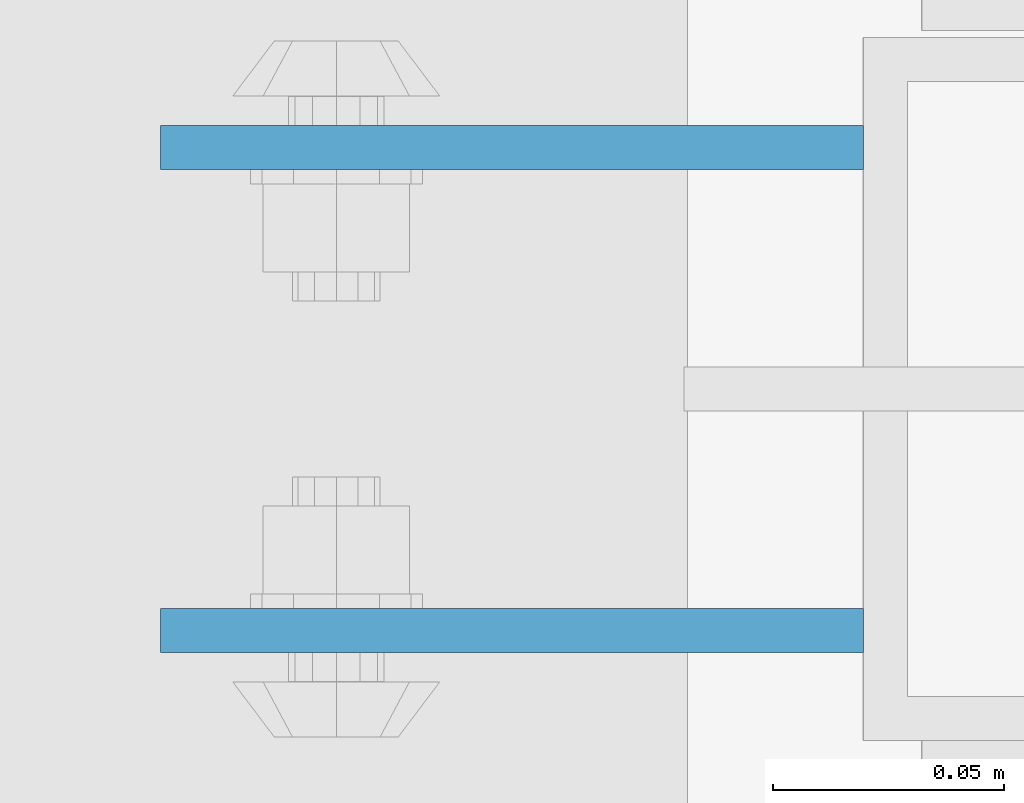
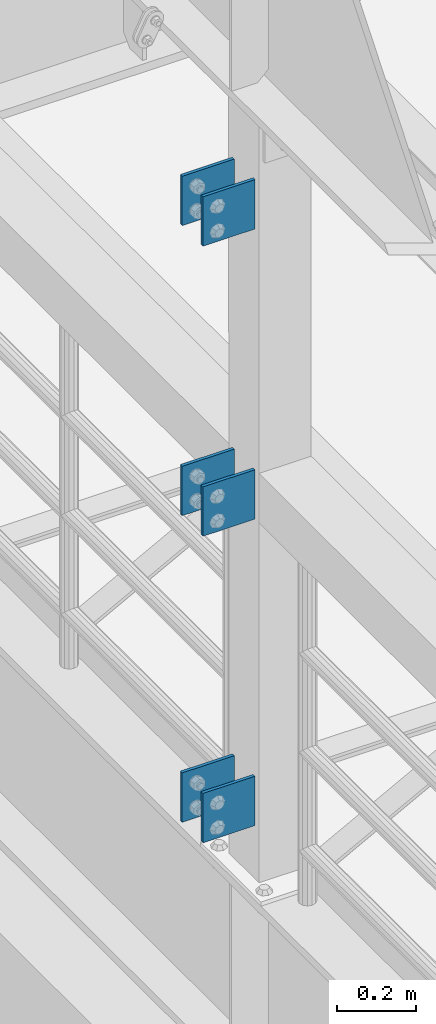
# One storey, part 1182 of 1876: 6 beams, 1 element without a shape of its own.
"""IFC2X3 building model written with IfcOpenShell, lengths in millimetres."""

import ifcopenshell
import ifcopenshell.guid

model = None  # the IFC model being written
_history = None  # IfcOwnerHistory: only IFC2X3 demands one
_inside = {}  # id of a spatial element -> (the spatial element, [elements in it])
_under = {}  # id of a project, library or spatial element -> (it, [spatial elements below it])
_declared = {}  # id of a project -> (the project, [libraries it declares])
_typed = {}  # id of a type object -> (the type object, [elements of that type])
_made_of = {}  # id of a material, layer set ... -> (it, [elements and type objects made of it])


def new_model(schema):
    """Start an empty IFC model of exactly this schema.

    Asked for "IFC4X3", IfcOpenShell would pick the latest addendum, in which some entities
    have other attributes; the version numbers below select the first issue.
    IFC2X3 requires an IfcOwnerHistory on every rooted entity: one is made here for all.
    """
    global model, _history
    if schema == "IFC4X3":
        model = ifcopenshell.file(schema_version=(4, 3, 0, 0))
    else:
        model = ifcopenshell.file(schema=schema)
    _inside.clear()
    _under.clear()
    _declared.clear()
    _typed.clear()
    _made_of.clear()
    _history = None
    if model.schema == "IFC2X3":
        org = make("IfcOrganization", Name="unknown")
        user = make(
            "IfcPersonAndOrganization",
            ThePerson=make("IfcPerson", FamilyName="unknown"),
            TheOrganization=org,
        )
        app = make(
            "IfcApplication",
            ApplicationDeveloper=org,
            Version="unknown",
            ApplicationFullName="unknown",
            ApplicationIdentifier="unknown",
        )
        _history = make(
            "IfcOwnerHistory",
            OwningUser=user,
            OwningApplication=app,
            ChangeAction="ADDED",
            CreationDate=0,
        )
    return model


def make(cls, **values):
    """One entity of the class cls with the attributes given. An attribute that is None is left unset."""
    return model.create_entity(
        cls, **{name: value for name, value in values.items() if value is not None}
    )


def rooted(cls, **values):
    """An entity with a GlobalId (a new one), such as an element, a storey or a relation."""
    return make(cls, GlobalId=ifcopenshell.guid.new(), OwnerHistory=_history, **values)


def si_unit(unit_type, name, prefix=None):
    """IfcSIUnit, for example si_unit("LENGTHUNIT", "METRE", prefix="MILLI")."""
    return make("IfcSIUnit", UnitType=unit_type, Prefix=prefix, Name=name)


def assignment(units):
    """IfcUnitAssignment: the units of a project."""
    return None if units is None else make("IfcUnitAssignment", Units=units)


def point(xyz):
    """IfcCartesianPoint."""
    return None if xyz is None else make("IfcCartesianPoint", Coordinates=xyz)


def direction(xyz):
    """IfcDirection."""
    return None if xyz is None else make("IfcDirection", DirectionRatios=xyz)


def frame(location, z_axis=None, x_axis=None):
    """IfcAxis2Placement3D, a coordinate frame: its origin and axes. An axis left out is left unset."""
    return make(
        "IfcAxis2Placement3D",
        Location=point(location),
        Axis=direction(z_axis),
        RefDirection=direction(x_axis),
    )


def origin_with_axes():
    """The frame at (0, 0, 0) with the z axis (0, 0, 1) and the x axis (1, 0, 0) written out."""
    return frame((0.0, 0.0, 0.0), z_axis=(0.0, 0.0, 1.0), x_axis=(1.0, 0.0, 0.0))


def place(relative_to, where):
    """IfcLocalPlacement: puts the frame where relative to a parent placement (None: the world)."""
    return make(
        "IfcLocalPlacement", PlacementRelTo=relative_to, RelativePlacement=where
    )


def context(
    kind, dimensions, precision=None, world=None, true_north=None, identifier=None
):
    """IfcGeometricRepresentationContext, for example the 3D "Model" context."""
    return make(
        "IfcGeometricRepresentationContext",
        ContextIdentifier=identifier,
        ContextType=kind,
        CoordinateSpaceDimension=dimensions,
        Precision=precision,
        WorldCoordinateSystem=world,
        TrueNorth=true_north,
    )


def subcontext(parent, identifier, kind, view, scale=None):
    """IfcGeometricRepresentationSubContext, for example "Body" below "Model"."""
    return make(
        "IfcGeometricRepresentationSubContext",
        ContextIdentifier=identifier,
        ContextType=kind,
        ParentContext=parent,
        TargetScale=scale,
        TargetView=view,
    )


def project(units=None, contexts=None):
    """IfcProject with its units and contexts."""
    return rooted(
        "IfcProject",
        Name="project",
        RepresentationContexts=contexts,
        UnitsInContext=assignment(units),
    )


def spatial(cls, under=None, at=None, **own):
    """A site, building, storey or space (cls), placed at a placement, below another one or the project."""
    s = rooted(cls, ObjectPlacement=at, **own)
    if under is not None:
        _under.setdefault(under.id(), (under, []))[1].append(s)
    return s


def faces_of(points, faces, orient=None, outer=None):
    """IfcFace entities. A face is a list of loops; a loop is a list of indices into points, from 0.

    orient and outer hold one flag for each loop. By default every Orientation is true, the
    first loop of a face is its IfcFaceOuterBound and the others are IfcFaceBound.
    """
    made = []
    for i, loops in enumerate(faces):
        bounds = []
        for j, loop in enumerate(loops):
            is_outer = j == 0 if outer is None else outer[i][j]
            bounds.append(
                make(
                    "IfcFaceOuterBound" if is_outer else "IfcFaceBound",
                    Bound=make("IfcPolyLoop", Polygon=[points[k] for k in loop]),
                    Orientation=True if orient is None else orient[i][j],
                )
            )
        made.append(make("IfcFace", Bounds=bounds))
    return made


def faceted_brep(points, faces, orient=None, outer=None, voids=None):
    """IfcFacetedBrep: a solid bounded by flat faces; with voids (closed shells), ...WithVoids."""
    shared = [point(p) for p in points]
    hull = make("IfcClosedShell", CfsFaces=faces_of(shared, faces, orient, outer))
    if voids is None:
        return make("IfcFacetedBrep", Outer=hull)
    return make(
        "IfcFacetedBrepWithVoids",
        Outer=hull,
        Voids=[
            make(cls, CfsFaces=faces_of(shared, fs, o, b)) for cls, fs, o, b in voids
        ],
    )


def shape(context_of_items, identifier, shape_type, items):
    """IfcShapeRepresentation: the items that make up one representation, for example the "Body"."""
    return make(
        "IfcShapeRepresentation",
        ContextOfItems=context_of_items,
        RepresentationIdentifier=identifier,
        RepresentationType=shape_type,
        Items=items,
    )


def material(Name=None, Category=None):
    """IfcMaterial."""
    return make("IfcMaterial", Name=Name, Category=Category)


def made_of(thing, what):
    """Note that an element or type object is made of a material, layer set ...; save() writes the relation."""
    if what is not None:
        _made_of.setdefault(what.id(), (what, []))[1].append(thing)
    return thing


def type_object(cls, material=None, **own):
    """A type object (cls), such as IfcWallType, which elements share."""
    return made_of(rooted(cls, **own), material)


def element(
    cls,
    number,
    at=None,
    inside=None,
    cuts=None,
    type_object=None,
    material=None,
    context=None,
    identifier="Body",
    shape_type=None,
    held_by="IfcProductDefinitionShape",
    body=None,
    shapes=None,
    **own,
):
    """One element of the class cls, such as IfcWall. Its Tag is "e" and its number.

    at: its placement. inside: the storey or other place that contains it. cuts: it is an
    opening in that element (IfcRelVoidsElement). A single representation is given by context,
    identifier, shape_type and body (its items); several are given by shapes. held_by: the class
    of the entity that holds the representations. save() writes the other relations.
    """
    e = rooted(cls, Tag="e%d" % number, ObjectPlacement=at, **own)
    if body is not None:
        shapes = [shape(context, identifier, shape_type, body)]
    if shapes is not None:
        e.Representation = make(held_by, Representations=shapes)
    if inside is not None:
        _inside.setdefault(inside.id(), (inside, []))[1].append(e)
    if cuts is not None:
        rooted(
            "IfcRelVoidsElement", RelatingBuildingElement=cuts, RelatedOpeningElement=e
        )
    if type_object is not None:
        _typed.setdefault(type_object.id(), (type_object, []))[1].append(e)
    return made_of(e, material)


def aggregate(whole, parts):
    """IfcRelAggregates: a whole, such as a stair, and the parts it consists of."""
    return rooted("IfcRelAggregates", RelatingObject=whole, RelatedObjects=parts)


def save(model, path):
    """Write the relations noted so far, then the file.

    IfcRelAggregates (storeys below a building ...), IfcRelContainedInSpatialStructure (elements
    in a storey), IfcRelDefinesByType, IfcRelAssociatesMaterial and IfcRelDeclares: one each for
    every whole, place, type object, material and project.
    """
    for whole, parts in _under.values():
        aggregate(whole, parts)
    for where, things in _inside.values():
        rooted(
            "IfcRelContainedInSpatialStructure",
            RelatedElements=things,
            RelatingStructure=where,
        )
    for kind, things in _typed.values():
        rooted("IfcRelDefinesByType", RelatedObjects=things, RelatingType=kind)
    for what, things in _made_of.values():
        rooted("IfcRelAssociatesMaterial", RelatedObjects=things, RelatingMaterial=what)
    for by, libraries in _declared.values():
        rooted("IfcRelDeclares", RelatingContext=by, RelatedDefinitions=libraries)
    model.write(path)


model = new_model("IFC2X3")

# Units and contexts
model_context = context("Model", 3, precision=1e-05, world=origin_with_axes())
body_context = subcontext(model_context, "Body", "Model", "MODEL_VIEW")
ifc_project = project(units=[si_unit("LENGTHUNIT", "METRE", prefix="MILLI"), si_unit("AREAUNIT", "SQUARE_METRE"), si_unit("VOLUMEUNIT", "CUBIC_METRE"), si_unit("MASSUNIT", "GRAM", prefix="KILO"), si_unit("TIMEUNIT", "SECOND"), si_unit("PLANEANGLEUNIT", "RADIAN"), si_unit("SOLIDANGLEUNIT", "STERADIAN"), si_unit("THERMODYNAMICTEMPERATUREUNIT", "DEGREE_CELSIUS"), si_unit("LUMINOUSINTENSITYUNIT", "LUMEN")], contexts=[model_context])

# Site, building, storey
site_placement = place(None, origin_with_axes())
site = spatial("IfcSite", under=ifc_project, at=site_placement, CompositionType="ELEMENT")
building_placement = place(site_placement, origin_with_axes())
building = spatial("IfcBuilding", under=site, at=building_placement, Name="Undefined", CompositionType="ELEMENT")
storey_placement = place(building_placement, origin_with_axes())
storey = spatial("IfcBuildingStorey", under=building, at=storey_placement, Name="Undefined", CompositionType="ELEMENT", Elevation=0.0)

# Assembly, beams
assembly_placement = place(storey_placement, origin_with_axes())
assembly = element("IfcElementAssembly", 1, at=assembly_placement, inside=storey, Name="BEAM", AssemblyPlace="NOTDEFINED", PredefinedType="RIGID_FRAME")
ifc_material = material(Name="STEEL/A36")
beam_type = type_object("IfcBeamType", PredefinedType="NOTDEFINED")
beam_1_placement = place(assembly_placement, frame((-76.2, -2487.6125, 6330.95), z_axis=(0.0, 0.0, -1.0), x_axis=(-1.0, 0.0, 0.0)))
beam_1 = element("IfcBeam", 2, at=beam_1_placement, type_object=beam_type, material=ifc_material, Name="PLATE", context=body_context, shape_type="Brep", body=[
    faceted_brep([(0.0, 4.76249999999982, -76.1999999999998), (3.63797880709171e-12, 4.76249999999982, 76.1999969482422), (152.399993896484, 4.76250000000073, 76.1999969482422), (152.4, 4.76249999999982, -76.1999999999998), (3.63797880709171e-12, -4.76249999999982, 76.1999969482422), (152.399993896484, -4.76250000000073, 76.1999969482422), (0.0, -4.76249999999982, -76.1999999999998), (152.4, -4.76249999999982, -76.1999999999998)], [[[0, 1, 2, 3]], [[4, 5, 2, 1]], [[4, 6, 7, 5]], [[6, 0, 3, 7]], [[5, 7, 3, 2]], [[6, 4, 1, 0]]]),
])
beam_2_placement = place(assembly_placement, frame((-76.2, -2592.3875, 6330.95), z_axis=(0.0, 0.0, -1.0), x_axis=(-1.0, 0.0, 0.0)))
beam_2 = element("IfcBeam", 3, at=beam_2_placement, type_object=beam_type, material=ifc_material, Name="PLATE", context=body_context, shape_type="Brep", body=[
    faceted_brep([(0.0, 4.76249999999982, -76.1999999999998), (3.63797880709171e-12, 4.76249999999982, 76.1999969482422), (152.399993896484, 4.76250000000073, 76.1999969482422), (152.4, 4.76249999999982, -76.1999999999998), (3.63797880709171e-12, -4.76249999999982, 76.1999969482422), (152.399993896484, -4.76250000000073, 76.1999969482422), (0.0, -4.76249999999982, -76.1999999999998), (152.4, -4.76249999999982, -76.1999999999998)], [[[0, 1, 2, 3]], [[4, 5, 2, 1]], [[4, 6, 7, 5]], [[6, 0, 3, 7]], [[5, 7, 3, 2]], [[6, 4, 1, 0]]]),
])
beam_3_placement = place(assembly_placement, frame((-76.2, -2487.6125, 7226.3), z_axis=(0.0, 0.0, -1.0), x_axis=(-1.0, 0.0, 0.0)))
beam_3 = element("IfcBeam", 4, at=beam_3_placement, type_object=beam_type, material=ifc_material, Name="PLATE", context=body_context, shape_type="Brep", body=[
    faceted_brep([(0.0, 4.76249999999982, -76.1999999999998), (3.63797880709171e-12, 4.76249999999982, 76.1999969482422), (152.399993896484, 4.76250000000073, 76.1999969482422), (152.4, 4.76249999999982, -76.1999999999998), (3.63797880709171e-12, -4.76249999999982, 76.1999969482422), (152.399993896484, -4.76250000000073, 76.1999969482422), (0.0, -4.76249999999982, -76.1999999999998), (152.4, -4.76249999999982, -76.1999999999998)], [[[0, 1, 2, 3]], [[4, 5, 2, 1]], [[4, 6, 7, 5]], [[6, 0, 3, 7]], [[5, 7, 3, 2]], [[6, 4, 1, 0]]]),
])
beam_4_placement = place(assembly_placement, frame((-76.2, -2592.3875, 7226.3), z_axis=(0.0, 0.0, -1.0), x_axis=(-1.0, 0.0, 0.0)))
beam_4 = element("IfcBeam", 5, at=beam_4_placement, type_object=beam_type, material=ifc_material, Name="PLATE", context=body_context, shape_type="Brep", body=[
    faceted_brep([(0.0, 4.76249999999982, -76.1999999999998), (3.63797880709171e-12, 4.76249999999982, 76.1999969482422), (152.399993896484, 4.76250000000073, 76.1999969482422), (152.4, 4.76249999999982, -76.1999999999998), (3.63797880709171e-12, -4.76249999999982, 76.1999969482422), (152.399993896484, -4.76250000000073, 76.1999969482422), (0.0, -4.76249999999982, -76.1999999999998), (152.4, -4.76249999999982, -76.1999999999998)], [[[0, 1, 2, 3]], [[4, 5, 2, 1]], [[4, 6, 7, 5]], [[6, 0, 3, 7]], [[5, 7, 3, 2]], [[6, 4, 1, 0]]]),
])
beam_5_placement = place(assembly_placement, frame((-76.2, -2487.6125, 5384.8), z_axis=(0.0, 0.0, -1.0), x_axis=(-1.0, 0.0, 0.0)))
beam_5 = element("IfcBeam", 6, at=beam_5_placement, type_object=beam_type, material=ifc_material, Name="PLATE", context=body_context, shape_type="Brep", body=[
    faceted_brep([(0.0, 4.76249999999982, -76.1999999999998), (3.63797880709171e-12, 4.76249999999982, 76.1999969482422), (152.399993896484, 4.76250000000073, 76.1999969482422), (152.4, 4.76249999999982, -76.1999999999998), (3.63797880709171e-12, -4.76249999999982, 76.1999969482422), (152.399993896484, -4.76250000000073, 76.1999969482422), (0.0, -4.76249999999982, -76.1999999999998), (152.4, -4.76249999999982, -76.1999999999998)], [[[0, 1, 2, 3]], [[4, 5, 2, 1]], [[4, 6, 7, 5]], [[6, 0, 3, 7]], [[5, 7, 3, 2]], [[6, 4, 1, 0]]]),
])
beam_6_placement = place(assembly_placement, frame((-76.2, -2592.3875, 5384.8), z_axis=(0.0, 0.0, -1.0), x_axis=(-1.0, 0.0, 0.0)))
beam_6 = element("IfcBeam", 7, at=beam_6_placement, type_object=beam_type, material=ifc_material, Name="PLATE", context=body_context, shape_type="Brep", body=[
    faceted_brep([(0.0, 4.76249999999982, -76.1999999999998), (3.63797880709171e-12, 4.76249999999982, 76.1999969482422), (152.399993896484, 4.76250000000073, 76.1999969482422), (152.4, 4.76249999999982, -76.1999999999998), (3.63797880709171e-12, -4.76249999999982, 76.1999969482422), (152.399993896484, -4.76250000000073, 76.1999969482422), (0.0, -4.76249999999982, -76.1999999999998), (152.4, -4.76249999999982, -76.1999999999998)], [[[0, 1, 2, 3]], [[4, 5, 2, 1]], [[4, 6, 7, 5]], [[6, 0, 3, 7]], [[5, 7, 3, 2]], [[6, 4, 1, 0]]]),
])
aggregate(assembly, [beam_1, beam_2, beam_3, beam_4, beam_5, beam_6])

save(model, "model.ifc")
